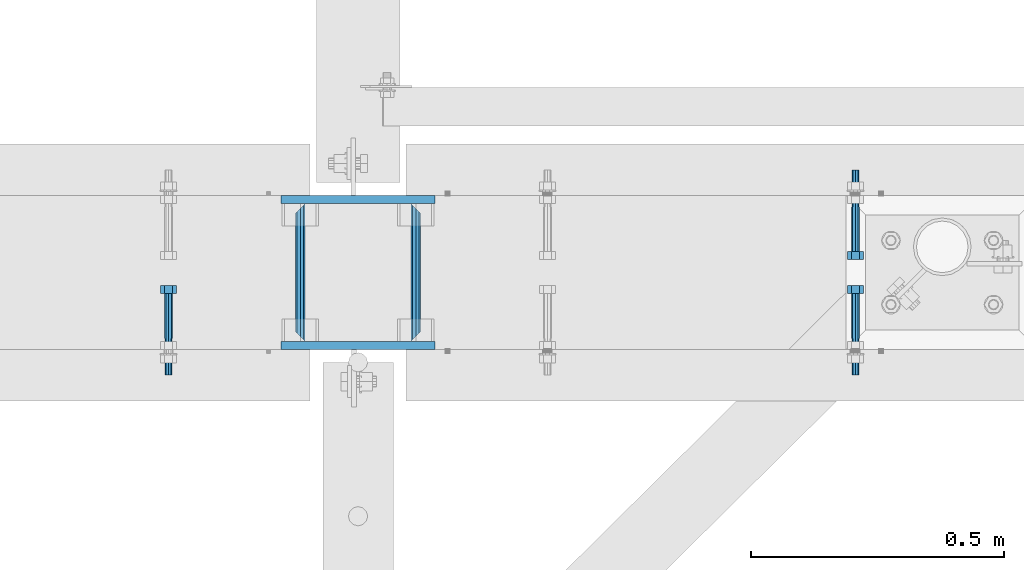
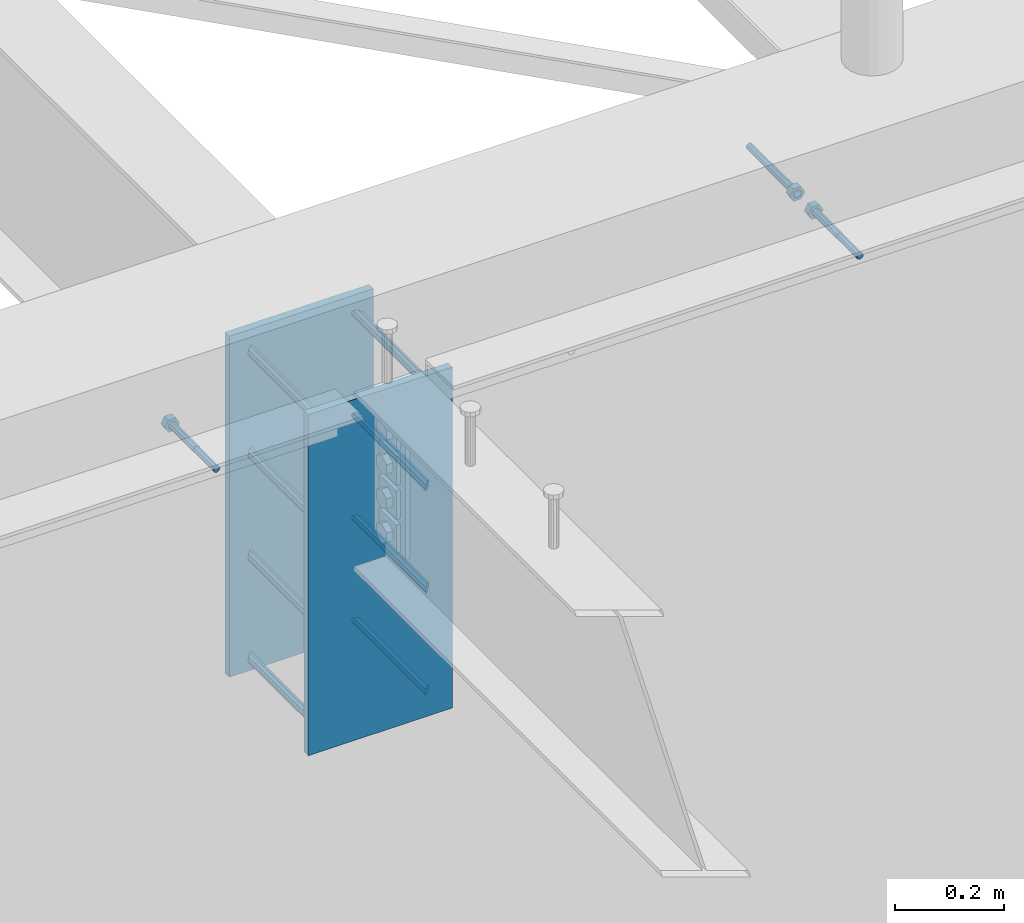
# One storey, part 430 of 975: 13 beams.
"""IFC2X3 building model written with IfcOpenShell, lengths in millimetres."""

from ifc_helpers import new_model, si_unit, frame, origin_with_axes, place, context, subcontext, project, spatial, faceted_brep, material, type_object, element, save


model = new_model("IFC2X3")

# Units and contexts
model_context = context("Model", 3, precision=1e-05, world=origin_with_axes())
body_context = subcontext(model_context, "Body", "Model", "MODEL_VIEW")
ifc_project = project(units=[si_unit("LENGTHUNIT", "METRE", prefix="MILLI"), si_unit("AREAUNIT", "SQUARE_METRE"), si_unit("VOLUMEUNIT", "CUBIC_METRE"), si_unit("MASSUNIT", "GRAM", prefix="KILO"), si_unit("TIMEUNIT", "SECOND"), si_unit("PLANEANGLEUNIT", "RADIAN"), si_unit("SOLIDANGLEUNIT", "STERADIAN"), si_unit("THERMODYNAMICTEMPERATUREUNIT", "DEGREE_CELSIUS"), si_unit("LUMINOUSINTENSITYUNIT", "LUMEN")], contexts=[model_context])

# Site, building, storey
site_placement = place(None, origin_with_axes())
site = spatial("IfcSite", under=ifc_project, at=site_placement, CompositionType="ELEMENT")
building_placement = place(site_placement, origin_with_axes())
building = spatial("IfcBuilding", under=site, at=building_placement, Name="Undefined", CompositionType="ELEMENT")
storey_placement = place(building_placement, origin_with_axes())
storey = spatial("IfcBuildingStorey", under=building, at=storey_placement, Name="Undefined", CompositionType="ELEMENT", Elevation=0.0)

# Beams
ifc_material_1 = material(Name="STEEL/F1554-36")
beam_type_1 = type_object("IfcBeamType", PredefinedType="NOTDEFINED")
beam_1_placement = place(storey_placement, frame((7244.82086460169, 20726.3999996637, 3886.2), z_axis=(0.0, 0.0, -1.0), x_axis=(0.0, -1.0, 0.0)))
element("IfcBeam", 1, at=beam_1_placement, inside=storey, type_object=beam_type_1, material=ifc_material_1, Name="HEADED_ANCHOR_BOLT", context=body_context, shape_type="Brep", body=[
    faceted_brep([(88.9000000184824, 7.94000001861696, -13.7499999799138), (88.8999999527368, 15.8800000758411, 2.00943759409711e-08), (104.774999952569, 15.8800001213949, 6.97191353538074e-08), (104.775000018315, 7.94000006417082, -13.7499999302891), (88.900000064019, -7.94000009583215, -13.7499999799147), (104.775000063852, -7.9400000502792, -13.74999993029), (88.9000000438027, -15.880000153059, 2.00925569515675e-08), (104.775000043643, -15.8800001075042, 6.9716406869702e-08), (88.8999999780608, -7.94000009583488, 13.7500000200998), (104.774999977893, -7.94000005028101, 13.7500000697237), (88.8999999325279, 7.94000001861514, 13.7500000201007), (104.774999932361, 7.940000064169, 13.7500000697246), (88.9000000119959, 3.78780480527439, -7.86545778426807), (88.8999999957159, 6.82538844544797, -5.4430656647246), (88.8999999799416, 8.51112018845743, -1.94260763148395), (88.8999999677944, 8.51112018845652, 1.94260767167179), (88.8999999616899, 6.82538844544615, 5.44306570491244), (88.8999999628249, 3.78780480527257, 7.86545782445592), (88.8999999709849, -3.86089595849626e-08, 8.72999956233434), (88.8999999845473, -3.7878048824914, 7.8654578244541), (88.9000000008309, -6.82538852266407, 5.44306570491153), (88.9000000166052, -8.51112026567444, 1.94260767166998), (88.9000000287488, -8.51112026567353, -1.94260763148577), (88.9000000348606, -6.82538852266407, -5.44306566472642), (88.9000000337182, -3.78780488248958, -7.86545778426898), (88.9000000255583, -3.86080500902608e-08, -8.72999952214832), (104.775000025395, 6.94581103743985e-09, -8.72999947252447), (104.775000011829, 3.78780485082825, -7.86545773464422), (104.774999995549, 6.82538849100092, -5.44306561510075), (104.774999979774, 8.51112023401038, -1.9426075818601), (104.774999967627, 8.51112023401038, 1.94260772129564), (104.774999961523, 6.82538849100092, 5.44306575453629), (104.774999962658, 3.78780485082643, 7.86545787407977), (104.774999970818, 6.94399204803631e-09, 8.7299996119591), (104.77499998438, -3.78780483693754, 7.86545787407886), (104.775000000664, -6.82538847711112, 5.44306575453538), (104.775000016438, -8.51112022012057, 1.94260772129473), (104.775000028581, -8.51112022012057, -1.94260758186101), (104.775000034693, -6.82538847711021, -5.44306561510166), (104.775000033551, -3.78780483693663, -7.86545773464422), (-2.99107341561466e-07, -5.61266007567065, 5.61266007566792), (-4.22995071858168e-07, -7.93750000000728, 0.0), (104.774999998088, -7.93749999999, -4.45652403868735e-11), (104.774999998088, -5.61266007565791, 5.61266007562426), (-1.09139364212751e-11, 1.81898940354586e-12, 7.9375), (104.774999998095, 1.18234311230481e-11, 7.93749999995816), (2.99089151667431e-07, 5.61266007567428, 5.61266007566792), (104.774999998102, 5.61266007568065, 5.61266007562517), (4.22980519942939e-07, 7.93750000001091, 0.0), (104.77499999811, 7.93750000001364, -4.36557456851006e-11), (2.99089151667431e-07, 5.61266007567428, -5.61266007566792), (104.774999998102, 5.61266007568156, -5.61266007571339), (-1.09139364212751e-11, 1.81898940354586e-12, -7.9375), (104.774999998099, 1.2732925824821e-11, -7.93750000004547), (-73.0249999592124, 5.05157065939329, -5.0515715445581), (-73.0249999269472, -1.85405951924622e-07, -7.14400069976364), (-73.0249999328516, -5.0515710302052, -5.05157154455992), (-73.0249999734697, -7.14400018541073, -6.9975976657588e-07), (-73.0250000250016, -5.05157103020611, 5.05157014504039), (-73.0250000572705, -1.85406861419324e-07, 7.1439993002441), (-73.0250000513661, 5.05157065939238, 5.05157014503948), (-73.025000010748, 7.14399981459792, -6.99758857081179e-07), (0.00625003290042514, 5.05157085007795, -5.05157087849238), (0.00625006516929716, 5.27870724909008e-09, -7.1440000336961), (0.00625005926485755, -5.05157083952145, -5.05157087849329), (0.00625001864682417, -7.14399999472516, -3.36940502165817e-08), (0.00624996711121639, -5.05157083952145, 5.05157081110519), (0.00624993484598235, 5.2777977543883e-09, 7.14399996631164), (0.00624994074678398, 5.05157085007704, 5.05157081110701), (0.00624998136845534, 7.14400000528167, -3.36922312271781e-08), (-2.99107341561466e-07, -5.61266007567065, -5.61266007566792), (104.774999998092, -5.612660075657, -5.6126600757143)], [[[0, 1, 2, 3]], [[4, 0, 3, 5]], [[6, 4, 5, 7]], [[8, 6, 7, 9]], [[10, 8, 9, 11]], [[0, 4, 6, 8, 10, 1], [12, 13, 14, 15, 16, 17, 18, 19, 20, 21, 22, 23, 24, 25]], [[12, 25, 26, 27]], [[13, 12, 27, 28]], [[14, 13, 28, 29]], [[15, 14, 29, 30]], [[16, 15, 30, 31]], [[17, 16, 31, 32]], [[18, 17, 32, 33]], [[19, 18, 33, 34]], [[20, 19, 34, 35]], [[21, 20, 35, 36]], [[22, 21, 36, 37]], [[23, 22, 37, 38]], [[24, 23, 38, 39]], [[25, 24, 39, 26]], [[9, 7, 5, 3, 2, 11], [38, 37, 36, 35, 34, 33, 32, 31, 30, 29, 28, 27, 26, 39]], [[1, 10, 11, 2]], [[40, 41, 42, 43]], [[44, 40, 43, 45]], [[46, 44, 45, 47]], [[48, 46, 47, 49]], [[50, 48, 49, 51]], [[52, 50, 51, 53]], [[54, 55, 56, 57, 58, 59, 60, 61]], [[55, 54, 62, 63]], [[56, 55, 63, 64]], [[57, 56, 64, 65]], [[58, 57, 65, 66]], [[59, 58, 66, 67]], [[60, 59, 67, 68]], [[61, 60, 68, 69]], [[54, 61, 69, 62]], [[40, 44, 46, 48, 50, 52, 70, 41], [68, 67, 66, 65, 64, 63, 62, 69]], [[41, 70, 71, 42]], [[53, 51, 49, 47, 45, 43, 42, 71]], [[70, 52, 53, 71]]]),
])
beam_2_placement = place(storey_placement, frame((7244.82086460169, 20466.05, 3886.2), z_axis=(0.0, 0.0, 1.0), x_axis=(0.0, 1.0, 0.0)))
element("IfcBeam", 2, at=beam_2_placement, inside=storey, type_object=beam_type_1, material=ifc_material_1, Name="HEADED_ANCHOR_BOLT", context=body_context, shape_type="Brep", body=[
    faceted_brep([(88.9000000184824, 7.94000001861696, -13.7499999799138), (88.8999999527368, 15.8800000758411, 2.00943759409711e-08), (104.774999952569, 15.8800001213949, 6.97191353538074e-08), (104.775000018315, 7.94000006417082, -13.7499999302891), (88.900000064019, -7.94000009583215, -13.7499999799147), (104.775000063852, -7.9400000502792, -13.74999993029), (88.9000000438027, -15.880000153059, 2.00925569515675e-08), (104.775000043643, -15.8800001075042, 6.9716406869702e-08), (88.8999999780608, -7.94000009583488, 13.7500000200998), (104.774999977893, -7.94000005028101, 13.7500000697237), (88.8999999325279, 7.94000001861514, 13.7500000201007), (104.774999932361, 7.940000064169, 13.7500000697246), (88.9000000119959, 3.78780480527439, -7.86545778426807), (88.8999999957159, 6.82538844544797, -5.4430656647246), (88.8999999799416, 8.51112018845743, -1.94260763148395), (88.8999999677944, 8.51112018845652, 1.94260767167179), (88.8999999616899, 6.82538844544615, 5.44306570491244), (88.8999999628249, 3.78780480527257, 7.86545782445592), (88.8999999709849, -3.86089595849626e-08, 8.72999956233434), (88.8999999845473, -3.7878048824914, 7.8654578244541), (88.9000000008309, -6.82538852266407, 5.44306570491153), (88.9000000166052, -8.51112026567444, 1.94260767166998), (88.9000000287488, -8.51112026567353, -1.94260763148577), (88.9000000348606, -6.82538852266407, -5.44306566472642), (88.9000000337182, -3.78780488248958, -7.86545778426898), (88.9000000255583, -3.86080500902608e-08, -8.72999952214832), (104.775000025395, 6.94581103743985e-09, -8.72999947252447), (104.775000011829, 3.78780485082825, -7.86545773464422), (104.774999995549, 6.82538849100092, -5.44306561510075), (104.774999979774, 8.51112023401038, -1.9426075818601), (104.774999967627, 8.51112023401038, 1.94260772129564), (104.774999961523, 6.82538849100092, 5.44306575453629), (104.774999962658, 3.78780485082643, 7.86545787407977), (104.774999970818, 6.94399204803631e-09, 8.7299996119591), (104.77499998438, -3.78780483693754, 7.86545787407886), (104.775000000664, -6.82538847711112, 5.44306575453538), (104.775000016438, -8.51112022012057, 1.94260772129473), (104.775000028581, -8.51112022012057, -1.94260758186101), (104.775000034693, -6.82538847711021, -5.44306561510166), (104.775000033551, -3.78780483693663, -7.86545773464422), (-2.99107341561466e-07, -5.61266007567065, 5.61266007566792), (-4.22995071858168e-07, -7.93750000000728, 0.0), (104.774999998088, -7.93749999999, -4.45652403868735e-11), (104.774999998088, -5.61266007565791, 5.61266007562426), (-1.09139364212751e-11, 1.81898940354586e-12, 7.9375), (104.774999998095, 1.18234311230481e-11, 7.93749999995816), (2.99089151667431e-07, 5.61266007567428, 5.61266007566792), (104.774999998102, 5.61266007568065, 5.61266007562517), (4.22980519942939e-07, 7.93750000001091, 0.0), (104.77499999811, 7.93750000001364, -4.36557456851006e-11), (2.99089151667431e-07, 5.61266007567428, -5.61266007566792), (104.774999998102, 5.61266007568156, -5.61266007571339), (-1.09139364212751e-11, 1.81898940354586e-12, -7.9375), (104.774999998099, 1.2732925824821e-11, -7.93750000004547), (-73.0249999592124, 5.05157065939329, -5.0515715445581), (-73.0249999269472, -1.85405951924622e-07, -7.14400069976364), (-73.0249999328516, -5.0515710302052, -5.05157154455992), (-73.0249999734697, -7.14400018541073, -6.9975976657588e-07), (-73.0250000250016, -5.05157103020611, 5.05157014504039), (-73.0250000572705, -1.85406861419324e-07, 7.1439993002441), (-73.0250000513661, 5.05157065939238, 5.05157014503948), (-73.025000010748, 7.14399981459792, -6.99758857081179e-07), (0.00625003290042514, 5.05157085007795, -5.05157087849238), (0.00625006516929716, 5.27870724909008e-09, -7.1440000336961), (0.00625005926485755, -5.05157083952145, -5.05157087849329), (0.00625001864682417, -7.14399999472516, -3.36940502165817e-08), (0.00624996711121639, -5.05157083952145, 5.05157081110519), (0.00624993484598235, 5.2777977543883e-09, 7.14399996631164), (0.00624994074678398, 5.05157085007704, 5.05157081110701), (0.00624998136845534, 7.14400000528167, -3.36922312271781e-08), (-2.99107341561466e-07, -5.61266007567065, -5.61266007566792), (104.774999998092, -5.612660075657, -5.6126600757143)], [[[0, 1, 2, 3]], [[4, 0, 3, 5]], [[6, 4, 5, 7]], [[8, 6, 7, 9]], [[10, 8, 9, 11]], [[0, 4, 6, 8, 10, 1], [12, 13, 14, 15, 16, 17, 18, 19, 20, 21, 22, 23, 24, 25]], [[12, 25, 26, 27]], [[13, 12, 27, 28]], [[14, 13, 28, 29]], [[15, 14, 29, 30]], [[16, 15, 30, 31]], [[17, 16, 31, 32]], [[18, 17, 32, 33]], [[19, 18, 33, 34]], [[20, 19, 34, 35]], [[21, 20, 35, 36]], [[22, 21, 36, 37]], [[23, 22, 37, 38]], [[24, 23, 38, 39]], [[25, 24, 39, 26]], [[9, 7, 5, 3, 2, 11], [38, 37, 36, 35, 34, 33, 32, 31, 30, 29, 28, 27, 26, 39]], [[1, 10, 11, 2]], [[40, 41, 42, 43]], [[44, 40, 43, 45]], [[46, 44, 45, 47]], [[48, 46, 47, 49]], [[50, 48, 49, 51]], [[52, 50, 51, 53]], [[54, 55, 56, 57, 58, 59, 60, 61]], [[55, 54, 62, 63]], [[56, 55, 63, 64]], [[57, 56, 64, 65]], [[58, 57, 65, 66]], [[59, 58, 66, 67]], [[60, 59, 67, 68]], [[61, 60, 68, 69]], [[54, 61, 69, 62]], [[40, 44, 46, 48, 50, 52, 70, 41], [68, 67, 66, 65, 64, 63, 62, 69]], [[41, 70, 71, 42]], [[53, 51, 49, 47, 45, 43, 42, 71]], [[70, 52, 53, 71]]]),
])
beam_3_placement = place(storey_placement, frame((5884.86256939269, 20466.05, 3886.2), z_axis=(0.0, 0.0, -1.0), x_axis=(0.0, 1.0, 0.0)))
element("IfcBeam", 3, at=beam_3_placement, inside=storey, type_object=beam_type_1, material=ifc_material_1, Name="HEADED_ANCHOR_BOLT", context=body_context, shape_type="Brep", body=[
    faceted_brep([(88.9000000184824, 7.94000001861696, -13.7499999799138), (88.8999999527368, 15.8800000758411, 2.00943759409711e-08), (104.774999952569, 15.8800001213949, 6.97191353538074e-08), (104.775000018315, 7.94000006417082, -13.7499999302891), (88.900000064019, -7.94000009583215, -13.7499999799147), (104.775000063852, -7.9400000502792, -13.74999993029), (88.9000000438027, -15.880000153059, 2.00925569515675e-08), (104.775000043643, -15.8800001075042, 6.9716406869702e-08), (88.8999999780608, -7.94000009583488, 13.7500000200998), (104.774999977893, -7.94000005028101, 13.7500000697237), (88.8999999325279, 7.94000001861514, 13.7500000201007), (104.774999932361, 7.940000064169, 13.7500000697246), (88.9000000119959, 3.78780480527439, -7.86545778426807), (88.8999999957159, 6.82538844544797, -5.4430656647246), (88.8999999799416, 8.51112018845743, -1.94260763148395), (88.8999999677944, 8.51112018845652, 1.94260767167179), (88.8999999616899, 6.82538844544615, 5.44306570491244), (88.8999999628249, 3.78780480527257, 7.86545782445592), (88.8999999709849, -3.86089595849626e-08, 8.72999956233434), (88.8999999845473, -3.7878048824914, 7.8654578244541), (88.9000000008309, -6.82538852266407, 5.44306570491153), (88.9000000166052, -8.51112026567444, 1.94260767166998), (88.9000000287488, -8.51112026567353, -1.94260763148577), (88.9000000348606, -6.82538852266407, -5.44306566472642), (88.9000000337182, -3.78780488248958, -7.86545778426898), (88.9000000255583, -3.86080500902608e-08, -8.72999952214832), (104.775000025395, 6.94581103743985e-09, -8.72999947252447), (104.775000011829, 3.78780485082825, -7.86545773464422), (104.774999995549, 6.82538849100092, -5.44306561510075), (104.774999979774, 8.51112023401038, -1.9426075818601), (104.774999967627, 8.51112023401038, 1.94260772129564), (104.774999961523, 6.82538849100092, 5.44306575453629), (104.774999962658, 3.78780485082643, 7.86545787407977), (104.774999970818, 6.94399204803631e-09, 8.7299996119591), (104.77499998438, -3.78780483693754, 7.86545787407886), (104.775000000664, -6.82538847711112, 5.44306575453538), (104.775000016438, -8.51112022012057, 1.94260772129473), (104.775000028581, -8.51112022012057, -1.94260758186101), (104.775000034693, -6.82538847711021, -5.44306561510166), (104.775000033551, -3.78780483693663, -7.86545773464422), (-2.99107341561466e-07, -5.61266007567065, 5.61266007566792), (-4.22995071858168e-07, -7.93750000000728, 0.0), (104.774999998088, -7.93749999999, -4.45652403868735e-11), (104.774999998088, -5.61266007565791, 5.61266007562426), (-1.09139364212751e-11, 1.81898940354586e-12, 7.9375), (104.774999998095, 1.18234311230481e-11, 7.93749999995816), (2.99089151667431e-07, 5.61266007567428, 5.61266007566792), (104.774999998102, 5.61266007568065, 5.61266007562517), (4.22980519942939e-07, 7.93750000001091, 0.0), (104.77499999811, 7.93750000001364, -4.36557456851006e-11), (2.99089151667431e-07, 5.61266007567428, -5.61266007566792), (104.774999998102, 5.61266007568156, -5.61266007571339), (-1.09139364212751e-11, 1.81898940354586e-12, -7.9375), (104.774999998099, 1.2732925824821e-11, -7.93750000004547), (-73.0249999592124, 5.05157065939329, -5.0515715445581), (-73.0249999269472, -1.85405951924622e-07, -7.14400069976364), (-73.0249999328516, -5.0515710302052, -5.05157154455992), (-73.0249999734697, -7.14400018541073, -6.9975976657588e-07), (-73.0250000250016, -5.05157103020611, 5.05157014504039), (-73.0250000572705, -1.85406861419324e-07, 7.1439993002441), (-73.0250000513661, 5.05157065939238, 5.05157014503948), (-73.025000010748, 7.14399981459792, -6.99758857081179e-07), (0.00625003290042514, 5.05157085007795, -5.05157087849238), (0.00625006516929716, 5.27870724909008e-09, -7.1440000336961), (0.00625005926485755, -5.05157083952145, -5.05157087849329), (0.00625001864682417, -7.14399999472516, -3.36940502165817e-08), (0.00624996711121639, -5.05157083952145, 5.05157081110519), (0.00624993484598235, 5.2777977543883e-09, 7.14399996631164), (0.00624994074678398, 5.05157085007704, 5.05157081110701), (0.00624998136845534, 7.14400000528167, -3.36922312271781e-08), (-2.99107341561466e-07, -5.61266007567065, -5.61266007566792), (104.774999998092, -5.612660075657, -5.6126600757143)], [[[0, 1, 2, 3]], [[4, 0, 3, 5]], [[6, 4, 5, 7]], [[8, 6, 7, 9]], [[10, 8, 9, 11]], [[0, 4, 6, 8, 10, 1], [12, 13, 14, 15, 16, 17, 18, 19, 20, 21, 22, 23, 24, 25]], [[12, 25, 26, 27]], [[13, 12, 27, 28]], [[14, 13, 28, 29]], [[15, 14, 29, 30]], [[16, 15, 30, 31]], [[17, 16, 31, 32]], [[18, 17, 32, 33]], [[19, 18, 33, 34]], [[20, 19, 34, 35]], [[21, 20, 35, 36]], [[22, 21, 36, 37]], [[23, 22, 37, 38]], [[24, 23, 38, 39]], [[25, 24, 39, 26]], [[9, 7, 5, 3, 2, 11], [38, 37, 36, 35, 34, 33, 32, 31, 30, 29, 28, 27, 26, 39]], [[1, 10, 11, 2]], [[40, 41, 42, 43]], [[44, 40, 43, 45]], [[46, 44, 45, 47]], [[48, 46, 47, 49]], [[50, 48, 49, 51]], [[52, 50, 51, 53]], [[54, 55, 56, 57, 58, 59, 60, 61]], [[55, 54, 62, 63]], [[56, 55, 63, 64]], [[57, 56, 64, 65]], [[58, 57, 65, 66]], [[59, 58, 66, 67]], [[60, 59, 67, 68]], [[61, 60, 68, 69]], [[54, 61, 69, 62]], [[40, 44, 46, 48, 50, 52, 70, 41], [68, 67, 66, 65, 64, 63, 62, 69]], [[41, 70, 71, 42]], [[53, 51, 49, 47, 45, 43, 42, 71]], [[70, 52, 53, 71]]]),
])
ifc_material_2 = material(Name="STEEL/A36")
beam_type_2 = type_object("IfcBeamType", PredefinedType="NOTDEFINED")
beam_4_placement = place(storey_placement, frame((6374.34172920507, 20459.7, 3403.6), z_axis=(0.0, 0.0, 1.0), x_axis=(0.0, 1.0, 0.0)))
element("IfcBeam", 4, at=beam_4_placement, inside=storey, type_object=beam_type_2, material=ifc_material_2, Name="ROD", context=body_context, shape_type="Brep", body=[
    faceted_brep([(19.0499992370605, -9.52499923706273, 0.0), (16.2601920907982, -6.73519209080223, 6.73519209080177), (9.52499999999782, 0.0, 9.52500000000009), (2.78980790919741, 6.73519209080223, 6.73519209080177), (0.0, 9.52499999999964, 0.0), (2.78980790919741, 6.73519209080223, -6.73519209080177), (9.52499999999782, 0.0, -9.52500000000009), (16.2601920907982, -6.73519209080223, -6.73519209080177), (273.050000000003, 9.52499999999782, 0.0), (270.260192090806, 6.73519209080223, 6.73519209080177), (263.525000000005, 0.0, 9.52500000000009), (256.789807909205, -6.73519209080223, 6.73519209080177), (254.000000762942, -9.52499999999964, 0.0), (256.789807909205, -6.73519209080223, -6.73519209080177), (263.525000000005, 0.0, -9.52500000000009), (270.260192090806, 6.73519209080223, -6.73519209080177)], [[[0, 1, 2, 3, 4, 5, 6, 7]], [[8, 9, 10, 11, 12, 13, 14, 15]], [[13, 12, 0, 7]], [[14, 13, 7, 6]], [[15, 14, 6, 5]], [[8, 15, 5, 4]], [[9, 8, 4, 3]], [[10, 9, 3, 2]], [[11, 10, 2, 1]], [[12, 11, 1, 0]]]),
])
beam_5_placement = place(storey_placement, frame((6145.74172920507, 20459.7, 3403.6), z_axis=(0.0, 0.0, 1.0), x_axis=(0.0, 1.0, 0.0)))
element("IfcBeam", 5, at=beam_5_placement, inside=storey, type_object=beam_type_2, material=ifc_material_2, Name="ROD", context=body_context, shape_type="Brep", body=[
    faceted_brep([(19.0499992370605, 9.52499923706091, 0.0), (16.2601920908019, 6.73519209080223, -6.73519209080177), (9.52499999999782, 0.0, -9.52500000000009), (2.78980790919741, -6.73519209080223, -6.73519209080177), (0.0, -9.52499999999964, 0.0), (2.78980790919741, -6.73519209080223, 6.73519209080177), (9.52499999999782, 0.0, 9.52500000000009), (16.2601920908019, 6.73519209080223, 6.73519209080177), (273.050000000003, -9.52499999999964, 0.0), (270.260192090806, -6.73519209080223, -6.73519209080177), (263.525000000005, 0.0, -9.52500000000009), (256.789807909201, 6.73519209080223, -6.73519209080177), (254.000000762942, 9.52499999999964, 0.0), (256.789807909201, 6.73519209080223, 6.73519209080177), (263.525000000005, 0.0, 9.52500000000009), (270.260192090806, -6.73519209080223, 6.73519209080177)], [[[0, 1, 2, 3, 4, 5, 6, 7]], [[8, 9, 10, 11, 12, 13, 14, 15]], [[13, 12, 0, 7]], [[14, 13, 7, 6]], [[15, 14, 6, 5]], [[8, 15, 5, 4]], [[9, 8, 4, 3]], [[10, 9, 3, 2]], [[11, 10, 2, 1]], [[12, 11, 1, 0]]]),
])
beam_6_placement = place(storey_placement, frame((6374.34172920507, 20459.7, 3632.2), z_axis=(0.0, 0.0, 1.0), x_axis=(0.0, 1.0, 0.0)))
element("IfcBeam", 6, at=beam_6_placement, inside=storey, type_object=beam_type_2, material=ifc_material_2, Name="ROD", context=body_context, shape_type="Brep", body=[
    faceted_brep([(19.0499992370605, -9.52499923706273, 0.0), (16.2601920907982, -6.73519209080223, 6.73519209080177), (9.52499999999782, 0.0, 9.52500000000009), (2.78980790919741, 6.73519209080223, 6.73519209080177), (0.0, 9.52499999999964, 0.0), (2.78980790919741, 6.73519209080223, -6.73519209080177), (9.52499999999782, 0.0, -9.52500000000009), (16.2601920907982, -6.73519209080223, -6.73519209080177), (273.050000000003, 9.52499999999782, 0.0), (270.260192090806, 6.73519209080223, 6.73519209080177), (263.525000000005, 0.0, 9.52500000000009), (256.789807909205, -6.73519209080223, 6.73519209080177), (254.000000762942, -9.52499999999964, 0.0), (256.789807909205, -6.73519209080223, -6.73519209080177), (263.525000000005, 0.0, -9.52500000000009), (270.260192090806, 6.73519209080223, -6.73519209080177)], [[[0, 1, 2, 3, 4, 5, 6, 7]], [[8, 9, 10, 11, 12, 13, 14, 15]], [[13, 12, 0, 7]], [[14, 13, 7, 6]], [[15, 14, 6, 5]], [[8, 15, 5, 4]], [[9, 8, 4, 3]], [[10, 9, 3, 2]], [[11, 10, 2, 1]], [[12, 11, 1, 0]]]),
])
beam_7_placement = place(storey_placement, frame((6145.74172920507, 20459.7, 3632.2), z_axis=(0.0, 0.0, 1.0), x_axis=(0.0, 1.0, 0.0)))
element("IfcBeam", 7, at=beam_7_placement, inside=storey, type_object=beam_type_2, material=ifc_material_2, Name="ROD", context=body_context, shape_type="Brep", body=[
    faceted_brep([(19.0499992370605, 9.52499923706091, 0.0), (16.2601920908019, 6.73519209080223, -6.73519209080177), (9.52499999999782, 0.0, -9.52500000000009), (2.78980790919741, -6.73519209080223, -6.73519209080177), (0.0, -9.52499999999964, 0.0), (2.78980790919741, -6.73519209080223, 6.73519209080177), (9.52499999999782, 0.0, 9.52500000000009), (16.2601920908019, 6.73519209080223, 6.73519209080177), (273.050000000003, -9.52499999999964, 0.0), (270.260192090806, -6.73519209080223, -6.73519209080177), (263.525000000005, 0.0, -9.52500000000009), (256.789807909201, 6.73519209080223, -6.73519209080177), (254.000000762942, 9.52499999999964, 0.0), (256.789807909201, 6.73519209080223, 6.73519209080177), (263.525000000005, 0.0, 9.52500000000009), (270.260192090806, -6.73519209080223, 6.73519209080177)], [[[0, 1, 2, 3, 4, 5, 6, 7]], [[8, 9, 10, 11, 12, 13, 14, 15]], [[13, 12, 0, 7]], [[14, 13, 7, 6]], [[15, 14, 6, 5]], [[8, 15, 5, 4]], [[9, 8, 4, 3]], [[10, 9, 3, 2]], [[11, 10, 2, 1]], [[12, 11, 1, 0]]]),
])
beam_8_placement = place(storey_placement, frame((6374.34172920507, 20459.7, 3175.0), z_axis=(0.0, 0.0, 1.0), x_axis=(0.0, 1.0, 0.0)))
element("IfcBeam", 8, at=beam_8_placement, inside=storey, type_object=beam_type_2, material=ifc_material_2, Name="ROD", context=body_context, shape_type="Brep", body=[
    faceted_brep([(19.0499992370605, -9.52499923706273, 0.0), (16.2601920907982, -6.73519209080223, 6.73519209080177), (9.52499999999782, 0.0, 9.52500000000009), (2.78980790919741, 6.73519209080223, 6.73519209080177), (0.0, 9.52499999999964, 0.0), (2.78980790919741, 6.73519209080223, -6.73519209080177), (9.52499999999782, 0.0, -9.52500000000009), (16.2601920907982, -6.73519209080223, -6.73519209080177), (273.050000000003, 9.52499999999782, 0.0), (270.260192090806, 6.73519209080223, 6.73519209080177), (263.525000000005, 0.0, 9.52500000000009), (256.789807909205, -6.73519209080223, 6.73519209080177), (254.000000762942, -9.52499999999964, 0.0), (256.789807909205, -6.73519209080223, -6.73519209080177), (263.525000000005, 0.0, -9.52500000000009), (270.260192090806, 6.73519209080223, -6.73519209080177)], [[[0, 1, 2, 3, 4, 5, 6, 7]], [[8, 9, 10, 11, 12, 13, 14, 15]], [[13, 12, 0, 7]], [[14, 13, 7, 6]], [[15, 14, 6, 5]], [[8, 15, 5, 4]], [[9, 8, 4, 3]], [[10, 9, 3, 2]], [[11, 10, 2, 1]], [[12, 11, 1, 0]]]),
])
beam_9_placement = place(storey_placement, frame((6145.74172920507, 20459.7, 3175.0), z_axis=(0.0, 0.0, 1.0), x_axis=(0.0, 1.0, 0.0)))
element("IfcBeam", 9, at=beam_9_placement, inside=storey, type_object=beam_type_2, material=ifc_material_2, Name="ROD", context=body_context, shape_type="Brep", body=[
    faceted_brep([(19.0499992370605, 9.52499923706091, 0.0), (16.2601920908019, 6.73519209080223, -6.73519209080177), (9.52499999999782, 0.0, -9.52500000000009), (2.78980790919741, -6.73519209080223, -6.73519209080177), (0.0, -9.52499999999964, 0.0), (2.78980790919741, -6.73519209080223, 6.73519209080177), (9.52499999999782, 0.0, 9.52500000000009), (16.2601920908019, 6.73519209080223, 6.73519209080177), (273.050000000003, -9.52499999999964, 0.0), (270.260192090806, -6.73519209080223, -6.73519209080177), (263.525000000005, 0.0, -9.52500000000009), (256.789807909201, 6.73519209080223, -6.73519209080177), (254.000000762942, 9.52499999999964, 0.0), (256.789807909201, 6.73519209080223, 6.73519209080177), (263.525000000005, 0.0, 9.52500000000009), (270.260192090806, -6.73519209080223, 6.73519209080177)], [[[0, 1, 2, 3, 4, 5, 6, 7]], [[8, 9, 10, 11, 12, 13, 14, 15]], [[13, 12, 0, 7]], [[14, 13, 7, 6]], [[15, 14, 6, 5]], [[8, 15, 5, 4]], [[9, 8, 4, 3]], [[10, 9, 3, 2]], [[11, 10, 2, 1]], [[12, 11, 1, 0]]]),
])
beam_10_placement = place(storey_placement, frame((6374.34172920507, 20459.7, 3860.8), z_axis=(0.0, 0.0, 1.0), x_axis=(0.0, 1.0, 0.0)))
element("IfcBeam", 10, at=beam_10_placement, inside=storey, type_object=beam_type_2, material=ifc_material_2, Name="ROD", context=body_context, shape_type="Brep", body=[
    faceted_brep([(19.0499992370605, -9.52499923706273, 0.0), (16.2601920907982, -6.73519209080223, 6.73519209080177), (9.52499999999782, 0.0, 9.52500000000009), (2.78980790919741, 6.73519209080223, 6.73519209080177), (0.0, 9.52499999999964, 0.0), (2.78980790919741, 6.73519209080223, -6.73519209080177), (9.52499999999782, 0.0, -9.52500000000009), (16.2601920907982, -6.73519209080223, -6.73519209080177), (273.050000000003, 9.52499999999782, 0.0), (270.260192090806, 6.73519209080223, 6.73519209080177), (263.525000000005, 0.0, 9.52500000000009), (256.789807909205, -6.73519209080223, 6.73519209080177), (254.000000762942, -9.52499999999964, 0.0), (256.789807909205, -6.73519209080223, -6.73519209080177), (263.525000000005, 0.0, -9.52500000000009), (270.260192090806, 6.73519209080223, -6.73519209080177)], [[[0, 1, 2, 3, 4, 5, 6, 7]], [[8, 9, 10, 11, 12, 13, 14, 15]], [[13, 12, 0, 7]], [[14, 13, 7, 6]], [[15, 14, 6, 5]], [[8, 15, 5, 4]], [[9, 8, 4, 3]], [[10, 9, 3, 2]], [[11, 10, 2, 1]], [[12, 11, 1, 0]]]),
])
beam_11_placement = place(storey_placement, frame((6145.74172920507, 20459.7, 3860.8), z_axis=(0.0, 0.0, 1.0), x_axis=(0.0, 1.0, 0.0)))
element("IfcBeam", 11, at=beam_11_placement, inside=storey, type_object=beam_type_2, material=ifc_material_2, Name="ROD", context=body_context, shape_type="Brep", body=[
    faceted_brep([(19.0499992370605, 9.52499923706091, 0.0), (16.2601920908019, 6.73519209080223, -6.73519209080177), (9.52499999999782, 0.0, -9.52500000000009), (2.78980790919741, -6.73519209080223, -6.73519209080177), (0.0, -9.52499999999964, 0.0), (2.78980790919741, -6.73519209080223, 6.73519209080177), (9.52499999999782, 0.0, 9.52500000000009), (16.2601920908019, 6.73519209080223, 6.73519209080177), (273.050000000003, -9.52499999999964, 0.0), (270.260192090806, -6.73519209080223, -6.73519209080177), (263.525000000005, 0.0, -9.52500000000009), (256.789807909201, 6.73519209080223, -6.73519209080177), (254.000000762942, 9.52499999999964, 0.0), (256.789807909201, 6.73519209080223, 6.73519209080177), (263.525000000005, 0.0, 9.52500000000009), (270.260192090806, -6.73519209080223, 6.73519209080177)], [[[0, 1, 2, 3, 4, 5, 6, 7]], [[8, 9, 10, 11, 12, 13, 14, 15]], [[13, 12, 0, 7]], [[14, 13, 7, 6]], [[15, 14, 6, 5]], [[8, 15, 5, 4]], [[9, 8, 4, 3]], [[10, 9, 3, 2]], [[11, 10, 2, 1]], [[12, 11, 1, 0]]]),
])
beam_type_3 = type_object("IfcBeamType", PredefinedType="NOTDEFINED")
for number, where, z_axis, x_axis, name in (
    (12, (6107.64172920507, 20451.7625, 3517.9), (0.0, 0.0, 1.0), (1.0, 0.0, 0.0), "EMBED_PLATE"),
    (13, (6107.64172920507, 20740.6875, 3517.9), (0.0, 0.0, 1.0), (1.0, 0.0, 0.0), "EMBED_PLATE"),
):
    element("IfcBeam", number, at=place(storey_placement, frame(where, z_axis=z_axis, x_axis=x_axis)), inside=storey, type_object=beam_type_3, material=ifc_material_2, Name=name, context=body_context, shape_type="Brep", body=[
        faceted_brep([(0.0, 7.9375, -381.0), (0.0, 7.9375, 381.0), (304.800000000001, 7.9375, 381.0), (304.800000000001, 7.9375, -381.0), (0.0, -7.9375, 381.0), (304.800000000001, -7.9375, 381.0), (0.0, -7.9375, -381.0), (304.800000000001, -7.9375, -381.0)], [[[0, 1, 2, 3]], [[1, 4, 5, 2]], [[4, 6, 7, 5]], [[6, 0, 3, 7]], [[5, 7, 3, 2]], [[6, 4, 1, 0]]]),
    ])

save(model, "model.ifc")
